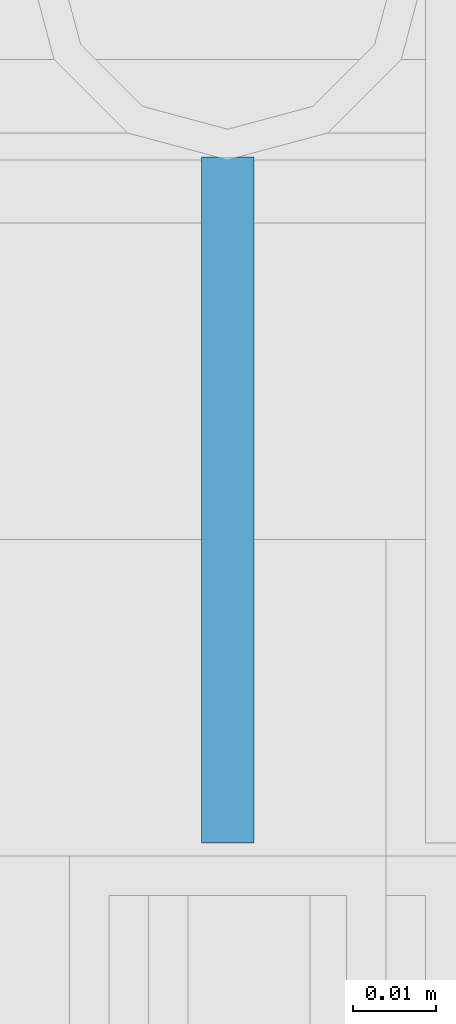
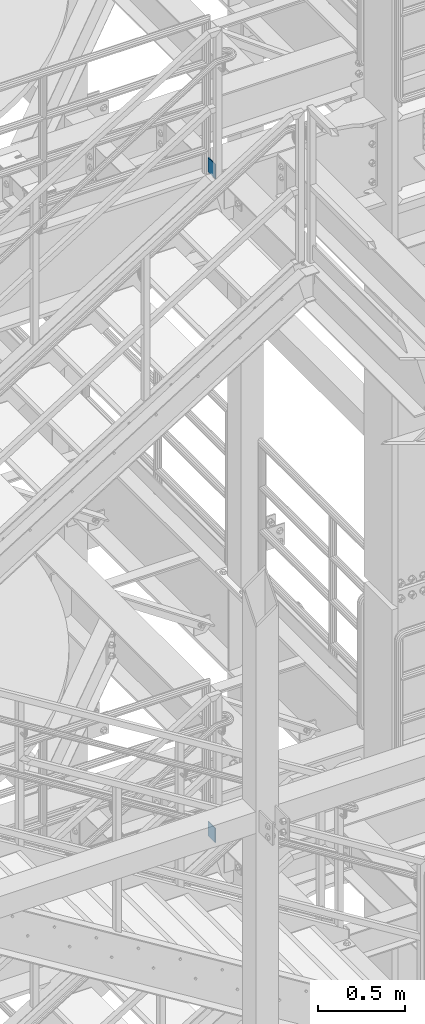
# One storey, part 1205 of 1876: 2 beams, 2 elements without a shape of their own.
"""IFC2X3 building model written with IfcOpenShell, lengths in millimetres."""

from ifc_helpers import new_model, si_unit, frame, origin_with_axes, place, context, subcontext, project, spatial, faceted_brep, material, type_object, element, aggregate, save


model = new_model("IFC2X3")

# Units and contexts
model_context = context("Model", 3, precision=1e-05, world=origin_with_axes())
body_context = subcontext(model_context, "Body", "Model", "MODEL_VIEW")
ifc_project = project(units=[si_unit("LENGTHUNIT", "METRE", prefix="MILLI"), si_unit("AREAUNIT", "SQUARE_METRE"), si_unit("VOLUMEUNIT", "CUBIC_METRE"), si_unit("MASSUNIT", "GRAM", prefix="KILO"), si_unit("TIMEUNIT", "SECOND"), si_unit("PLANEANGLEUNIT", "RADIAN"), si_unit("SOLIDANGLEUNIT", "STERADIAN"), si_unit("THERMODYNAMICTEMPERATUREUNIT", "DEGREE_CELSIUS"), si_unit("LUMINOUSINTENSITYUNIT", "LUMEN")], contexts=[model_context])

# Site, building, storey
site_placement = place(None, origin_with_axes())
site = spatial("IfcSite", under=ifc_project, at=site_placement, CompositionType="ELEMENT")
building_placement = place(site_placement, origin_with_axes())
building = spatial("IfcBuilding", under=site, at=building_placement, Name="Undefined", CompositionType="ELEMENT")
storey_placement = place(building_placement, origin_with_axes())
storey = spatial("IfcBuildingStorey", under=building, at=storey_placement, Name="Undefined", CompositionType="ELEMENT", Elevation=0.0)

# Assembly, beam
assembly_1_placement = place(storey_placement, origin_with_axes())
assembly_1 = element("IfcElementAssembly", 1, at=assembly_1_placement, inside=storey, Name="RAIL", AssemblyPlace="NOTDEFINED", PredefinedType="RIGID_FRAME")
ifc_material = material(Name="STEEL/A36")
beam_type = type_object("IfcBeamType", PredefinedType="NOTDEFINED")
beam_1_placement = place(assembly_1_placement, frame((6137.27549990582, -4678.36250109789, 18049.875), z_axis=(0.0, 0.0, 1.0), x_axis=(0.0, -1.0, 0.0)))
beam_1 = element("IfcBeam", 2, at=beam_1_placement, type_object=beam_type, material=ifc_material, Name="PLATE", context=body_context, shape_type="Brep", body=[
    faceted_brep([(0.0, 3.17500000000018, -50.8000000000002), (0.0, 3.17500000000018, 50.8000000000002), (82.5499996667077, 3.17500000003656, 50.7999999999993), (82.5499996667077, 3.17500000003656, -50.7999999999993), (0.0, -3.17500000000018, 50.8000000000002), (82.5499996667095, -3.1749999999638, 50.7999999999993), (0.0, -3.17500000000018, -50.8000000000002), (82.5499996667095, -3.1749999999638, -50.7999999999993)], [[[0, 1, 2, 3]], [[1, 4, 5, 2]], [[4, 6, 7, 5]], [[6, 0, 3, 7]], [[5, 7, 3, 2]], [[6, 4, 1, 0]]]),
])
aggregate(assembly_1, [beam_1])

assembly_2_placement = place(storey_placement, origin_with_axes())
assembly_2 = element("IfcElementAssembly", 3, at=assembly_2_placement, inside=storey, Name="RAIL", AssemblyPlace="NOTDEFINED", PredefinedType="RIGID_FRAME")
beam_2_placement = place(assembly_2_placement, frame((6137.27549990582, -4678.36250109789, 13376.275), z_axis=(0.0, 0.0, 1.0), x_axis=(0.0, -1.0, 0.0)))
beam_2 = element("IfcBeam", 4, at=beam_2_placement, type_object=beam_type, material=ifc_material, Name="PLATE", context=body_context, shape_type="Brep", body=[
    faceted_brep([(0.0, 3.17500000000018, -50.8000000000002), (0.0, 3.17500000000018, 50.8000000000002), (82.5499996667077, 3.17500000003656, 50.7999999999993), (82.5499996667077, 3.17500000003656, -50.7999999999993), (0.0, -3.17500000000018, 50.8000000000002), (82.5499996667095, -3.1749999999638, 50.7999999999993), (0.0, -3.17500000000018, -50.8000000000002), (82.5499996667095, -3.1749999999638, -50.7999999999993)], [[[0, 1, 2, 3]], [[1, 4, 5, 2]], [[4, 6, 7, 5]], [[6, 0, 3, 7]], [[5, 7, 3, 2]], [[6, 4, 1, 0]]]),
])
aggregate(assembly_2, [beam_2])

save(model, "model.ifc")
